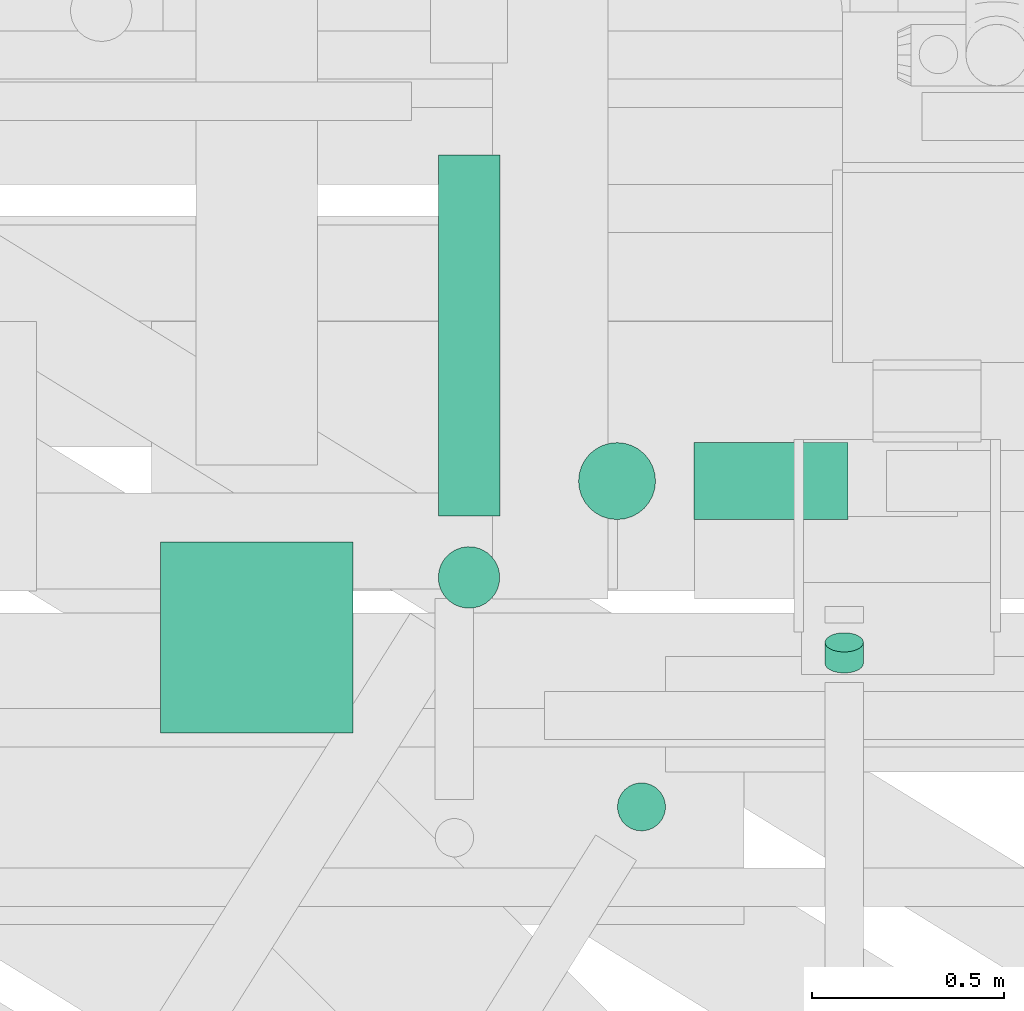
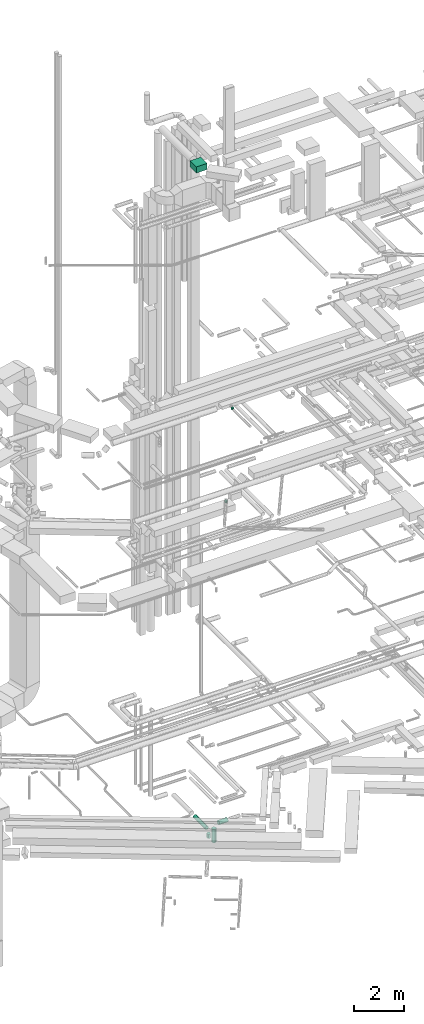
# One storey, part 93 of 337: 7 flow segments.
"""IFC2X3 building model written with IfcOpenShell, lengths in millimetres."""

from ifc_helpers import new_model, entity, si_unit, converted_unit, derived_unit, direction, frame, origin, origin_2d_with_axis, place, context, subcontext, project, spatial, rectangle, circle, extrude, type_object, element, save


model = new_model("IFC2X3")

# Units and contexts
model_context = context("Model", 3, precision=0.01, world=origin(), true_north=direction((6.12303176911189e-17, 1.0)))
body_context = subcontext(model_context, "Body", "Model", "MODEL_VIEW")
ifc_project = project(units=[si_unit("LENGTHUNIT", "METRE", prefix="MILLI"), si_unit("AREAUNIT", "SQUARE_METRE"), si_unit("VOLUMEUNIT", "CUBIC_METRE"), converted_unit("PLANEANGLEUNIT", "DEGREE", entity("IfcRatioMeasure", 0.0174532925199433), si_unit("PLANEANGLEUNIT", "RADIAN"), dimensions=[0, 0, 0, 0, 0, 0, 0]), si_unit("MASSUNIT", "GRAM", prefix="KILO"), derived_unit("MASSDENSITYUNIT", [(si_unit("MASSUNIT", "GRAM", prefix="KILO"), 1), (si_unit("LENGTHUNIT", "METRE"), -3)]), derived_unit("MOMENTOFINERTIAUNIT", [(si_unit("LENGTHUNIT", "METRE"), 4)]), si_unit("TIMEUNIT", "SECOND"), si_unit("FREQUENCYUNIT", "HERTZ"), si_unit("THERMODYNAMICTEMPERATUREUNIT", "DEGREE_CELSIUS"), derived_unit("THERMALTRANSMITTANCEUNIT", [(si_unit("MASSUNIT", "GRAM", prefix="KILO"), 1), (si_unit("THERMODYNAMICTEMPERATUREUNIT", "KELVIN"), -1), (si_unit("TIMEUNIT", "SECOND"), -3)]), derived_unit("VOLUMETRICFLOWRATEUNIT", [(si_unit("LENGTHUNIT", "METRE"), 3), (si_unit("TIMEUNIT", "SECOND"), -1)]), derived_unit("MASSFLOWRATEUNIT", [(si_unit("MASSUNIT", "GRAM", prefix="KILO"), 1), (si_unit("TIMEUNIT", "SECOND"), -1)]), derived_unit("ROTATIONALFREQUENCYUNIT", [(si_unit("TIMEUNIT", "SECOND"), -1)]), si_unit("ELECTRICCURRENTUNIT", "AMPERE"), si_unit("ELECTRICVOLTAGEUNIT", "VOLT"), si_unit("POWERUNIT", "WATT"), si_unit("FORCEUNIT", "NEWTON", prefix="KILO"), si_unit("ILLUMINANCEUNIT", "LUX"), si_unit("LUMINOUSFLUXUNIT", "LUMEN"), si_unit("LUMINOUSINTENSITYUNIT", "CANDELA"), derived_unit("USERDEFINED", [(si_unit("MASSUNIT", "GRAM", prefix="KILO"), -1), (si_unit("LENGTHUNIT", "METRE"), -2), (si_unit("TIMEUNIT", "SECOND"), 3), (si_unit("LUMINOUSFLUXUNIT", "LUMEN"), 1)]), derived_unit("LINEARVELOCITYUNIT", [(si_unit("LENGTHUNIT", "METRE"), 1), (si_unit("TIMEUNIT", "SECOND"), -1)]), si_unit("PRESSUREUNIT", "PASCAL"), derived_unit("USERDEFINED", [(si_unit("LENGTHUNIT", "METRE"), -2), (si_unit("MASSUNIT", "GRAM", prefix="KILO"), 1), (si_unit("TIMEUNIT", "SECOND"), -2)]), derived_unit("LINEARFORCEUNIT", [(si_unit("MASSUNIT", "GRAM", prefix="KILO"), 1), (si_unit("LENGTHUNIT", "METRE"), 1), (si_unit("TIMEUNIT", "SECOND"), -2), (si_unit("LENGTHUNIT", "METRE"), -1)]), derived_unit("PLANARFORCEUNIT", [(si_unit("MASSUNIT", "GRAM", prefix="KILO"), 1), (si_unit("LENGTHUNIT", "METRE"), 1), (si_unit("TIMEUNIT", "SECOND"), -2), (si_unit("LENGTHUNIT", "METRE"), -2)])], contexts=[model_context])

# Site, building, storey
site_placement = place(None, origin())
site = spatial("IfcSite", under=ifc_project, at=site_placement, CompositionType="ELEMENT")
building_placement = place(site_placement, origin())
building = spatial("IfcBuilding", under=site, at=building_placement, CompositionType="ELEMENT")
storey_placement = place(building_placement, origin())
storey = spatial("IfcBuildingStorey", under=building, at=storey_placement, CompositionType="ELEMENT", Elevation=0.0)

# Flow segments
duct_segment_type_1 = type_object("IfcDuctSegmentType", PredefinedType="NOTDEFINED")
flow_segment_1_placement = place(storey_placement, frame((8351.41, 10548.05, 31350.0)))
element("IfcFlowSegment", 1, at=flow_segment_1_placement, inside=storey, type_object=duct_segment_type_1, context=body_context, shape_type="SweptSolid", body=[
    extrude(rectangle(XDim=497.000000000002, YDim=500.0, at=origin_2d_with_axis()), frame((250.0, 248.5, 0.0), z_axis=(0.0, 0.0, 1.0), x_axis=(0.0, 1.0, 0.0)), (0.0, 0.0, 1.0), 300.000000000001),
])
duct_segment_type_2 = type_object("IfcDuctSegmentType", PredefinedType="NOTDEFINED")
flow_segment_2_placement = place(storey_placement, frame((9738.1, 11101.25, -1051.6)))
element("IfcFlowSegment", 2, at=flow_segment_2_placement, inside=storey, type_object=duct_segment_type_2, context=body_context, shape_type="SweptSolid", body=[
    extrude(circle(Radius=100.0, at=origin_2d_with_axis()), frame((0.0, 101.6, 101.6), z_axis=(1.0, 0.0, 0.0), x_axis=(0.0, 1.0, 0.0)), (0.0, 0.0, 1.0), 399.999999999994),
])
flow_segment_3_placement = place(storey_placement, frame((9436.51, 11101.25, -1793.02)))
element("IfcFlowSegment", 3, at=flow_segment_3_placement, inside=storey, type_object=duct_segment_type_2, context=body_context, shape_type="SweptSolid", body=[
    extrude(circle(Radius=100.0, at=origin_2d_with_axis()), frame((101.6, 101.6, 0.0), z_axis=(0.0, 0.0, 1.0), x_axis=(0.0, -1.0, 0.0)), (0.0, 0.0, 1.0), 643.019550628408),
])
flow_segment_4_placement = place(storey_placement, frame((9071.65, 11112.34, -1031.6)))
element("IfcFlowSegment", 4, at=flow_segment_4_placement, inside=storey, type_object=duct_segment_type_2, context=body_context, shape_type="SweptSolid", body=[
    extrude(circle(Radius=80.0, at=origin_2d_with_axis()), frame((81.6, 0.0, 81.6), z_axis=(0.0, 1.0, 0.0), x_axis=(1.0, 0.0, 0.0)), (0.0, 0.0, 1.0), 937.847362705442),
])
flow_segment_5_placement = place(storey_placement, frame((10077.02, 10702.4, 19168.5)))
element("IfcFlowSegment", 5, at=flow_segment_5_placement, inside=storey, type_object=duct_segment_type_2, context=body_context, shape_type="SweptSolid", body=[
    extrude(circle(Radius=50.0, at=origin_2d_with_axis()), frame((51.6, 26.6, 44.9), z_axis=(0.0, 0.866025000828383, 0.500000697939712), x_axis=(-1.0, 0.0, 0.0)), (0.0, 0.0, 1.0), 63.0241709962226),
])
flow_segment_6_placement = place(storey_placement, frame((9537.6, 10291.78, 15120.0)))
element("IfcFlowSegment", 6, at=flow_segment_6_placement, inside=storey, type_object=duct_segment_type_2, context=body_context, shape_type="SweptSolid", body=[
    extrude(circle(Radius=62.5, at=origin_2d_with_axis()), frame((64.06, 64.06, 0.0), z_axis=(0.0, 0.0, 1.0), x_axis=(-0.84871016255502, 0.528858260761645, 0.0)), (0.0, 0.0, 1.0), 79.9999959279379),
])
flow_segment_7_placement = place(storey_placement, frame((9071.71, 10870.8, -1310.0)))
element("IfcFlowSegment", 7, at=flow_segment_7_placement, inside=storey, type_object=duct_segment_type_2, context=body_context, shape_type="SweptSolid", body=[
    extrude(circle(Radius=80.0, at=origin_2d_with_axis()), frame((81.54, 81.54, 0.0), z_axis=(0.0, 0.0, 1.0), x_axis=(0.846428930081424, -0.532501705463199, 0.0)), (0.0, 0.0, 1.0), 200.000000000016),
])

save(model, "model.ifc")
